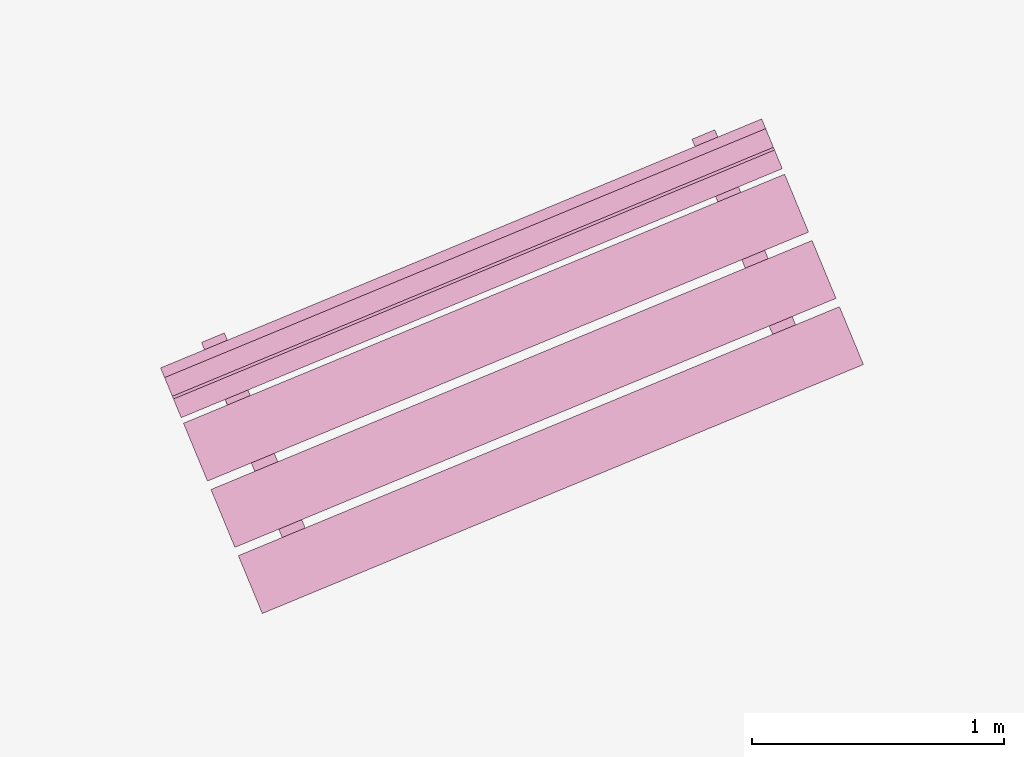
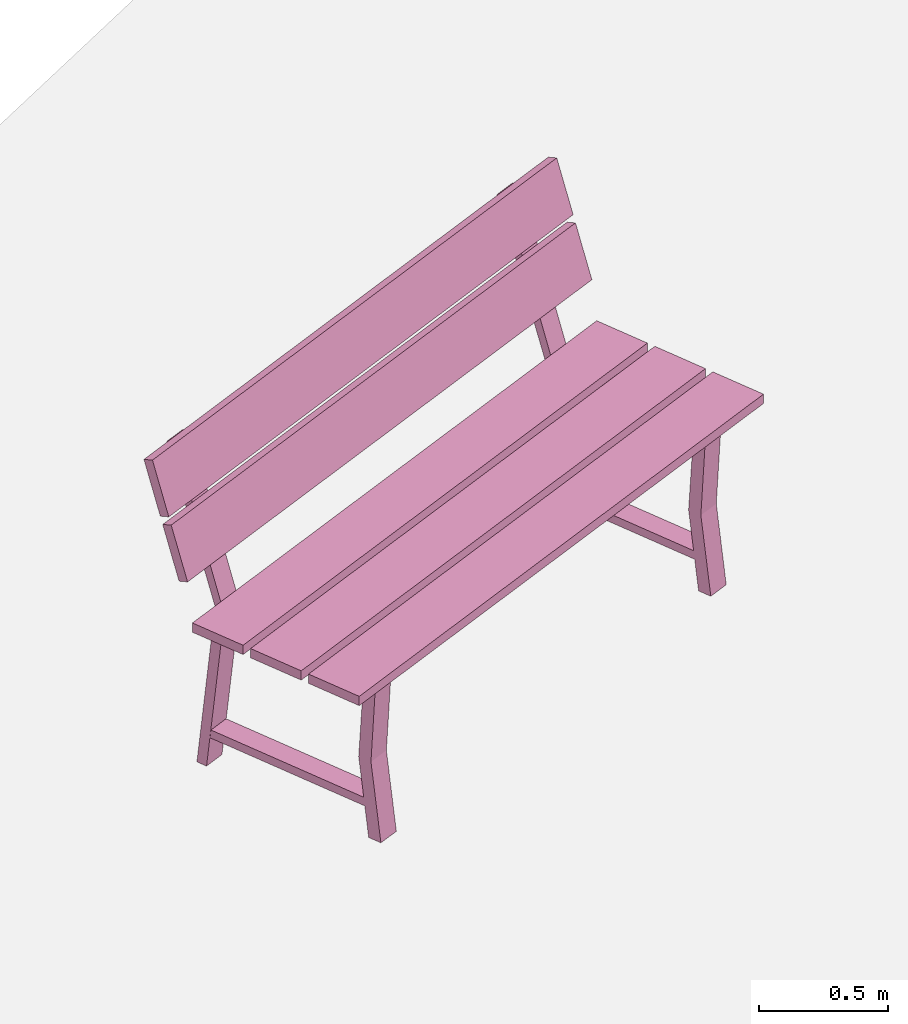
# One storey, part 17 of 200: 1 furnishing.
"""IFC4 building model written with IfcOpenShell, lengths in metres."""

import ifcopenshell
import ifcopenshell.guid

model = None  # the IFC model being written
_history = None  # IfcOwnerHistory: only IFC2X3 demands one
_inside = {}  # id of a spatial element -> (the spatial element, [elements in it])
_under = {}  # id of a project, library or spatial element -> (it, [spatial elements below it])
_declared = {}  # id of a project -> (the project, [libraries it declares])
_typed = {}  # id of a type object -> (the type object, [elements of that type])
_made_of = {}  # id of a material, layer set ... -> (it, [elements and type objects made of it])


def new_model(schema):
    """Start an empty IFC model of exactly this schema.

    Asked for "IFC4X3", IfcOpenShell would pick the latest addendum, in which some entities
    have other attributes; the version numbers below select the first issue.
    IFC2X3 requires an IfcOwnerHistory on every rooted entity: one is made here for all.
    """
    global model, _history
    if schema == "IFC4X3":
        model = ifcopenshell.file(schema_version=(4, 3, 0, 0))
    else:
        model = ifcopenshell.file(schema=schema)
    _inside.clear()
    _under.clear()
    _declared.clear()
    _typed.clear()
    _made_of.clear()
    _history = None
    if model.schema == "IFC2X3":
        org = make("IfcOrganization", Name="unknown")
        user = make(
            "IfcPersonAndOrganization",
            ThePerson=make("IfcPerson", FamilyName="unknown"),
            TheOrganization=org,
        )
        app = make(
            "IfcApplication",
            ApplicationDeveloper=org,
            Version="unknown",
            ApplicationFullName="unknown",
            ApplicationIdentifier="unknown",
        )
        _history = make(
            "IfcOwnerHistory",
            OwningUser=user,
            OwningApplication=app,
            ChangeAction="ADDED",
            CreationDate=0,
        )
    return model


def make(cls, **values):
    """One entity of the class cls with the attributes given. An attribute that is None is left unset."""
    return model.create_entity(
        cls, **{name: value for name, value in values.items() if value is not None}
    )


def rooted(cls, **values):
    """An entity with a GlobalId (a new one), such as an element, a storey or a relation."""
    return make(cls, GlobalId=ifcopenshell.guid.new(), OwnerHistory=_history, **values)


def si_unit(unit_type, name, prefix=None):
    """IfcSIUnit, for example si_unit("LENGTHUNIT", "METRE", prefix="MILLI")."""
    return make("IfcSIUnit", UnitType=unit_type, Prefix=prefix, Name=name)


def assignment(units):
    """IfcUnitAssignment: the units of a project."""
    return None if units is None else make("IfcUnitAssignment", Units=units)


def point(xyz):
    """IfcCartesianPoint."""
    return None if xyz is None else make("IfcCartesianPoint", Coordinates=xyz)


def direction(xyz):
    """IfcDirection."""
    return None if xyz is None else make("IfcDirection", DirectionRatios=xyz)


def frame(location, z_axis=None, x_axis=None):
    """IfcAxis2Placement3D, a coordinate frame: its origin and axes. An axis left out is left unset."""
    return make(
        "IfcAxis2Placement3D",
        Location=point(location),
        Axis=direction(z_axis),
        RefDirection=direction(x_axis),
    )


def origin_with_axes():
    """The frame at (0, 0, 0) with the z axis (0, 0, 1) and the x axis (1, 0, 0) written out."""
    return frame((0.0, 0.0, 0.0), z_axis=(0.0, 0.0, 1.0), x_axis=(1.0, 0.0, 0.0))


def place(relative_to, where):
    """IfcLocalPlacement: puts the frame where relative to a parent placement (None: the world)."""
    return make(
        "IfcLocalPlacement", PlacementRelTo=relative_to, RelativePlacement=where
    )


def context(
    kind, dimensions, precision=None, world=None, true_north=None, identifier=None
):
    """IfcGeometricRepresentationContext, for example the 3D "Model" context."""
    return make(
        "IfcGeometricRepresentationContext",
        ContextIdentifier=identifier,
        ContextType=kind,
        CoordinateSpaceDimension=dimensions,
        Precision=precision,
        WorldCoordinateSystem=world,
        TrueNorth=true_north,
    )


def subcontext(parent, identifier, kind, view, scale=None):
    """IfcGeometricRepresentationSubContext, for example "Body" below "Model"."""
    return make(
        "IfcGeometricRepresentationSubContext",
        ContextIdentifier=identifier,
        ContextType=kind,
        ParentContext=parent,
        TargetScale=scale,
        TargetView=view,
    )


def project(units=None, contexts=None):
    """IfcProject with its units and contexts."""
    return rooted(
        "IfcProject",
        Name="project",
        RepresentationContexts=contexts,
        UnitsInContext=assignment(units),
    )


def spatial(cls, under=None, at=None, **own):
    """A site, building, storey or space (cls), placed at a placement, below another one or the project."""
    s = rooted(cls, ObjectPlacement=at, **own)
    if under is not None:
        _under.setdefault(under.id(), (under, []))[1].append(s)
    return s


def point_list(points):
    """IfcCartesianPointList2D or 3D."""
    cls = (
        "IfcCartesianPointList2D" if len(points[0]) == 2 else "IfcCartesianPointList3D"
    )
    return make(cls, CoordList=points)


def triangles(points, corners, closed=None, point_numbers=None):
    """IfcTriangulatedFaceSet: each triangle names its three corners, points numbered from 1."""
    return make(
        "IfcTriangulatedFaceSet",
        Coordinates=point_list(points),
        Closed=closed,
        CoordIndex=corners,
        PnIndex=point_numbers,
    )


def shape(context_of_items, identifier, shape_type, items):
    """IfcShapeRepresentation: the items that make up one representation, for example the "Body"."""
    return make(
        "IfcShapeRepresentation",
        ContextOfItems=context_of_items,
        RepresentationIdentifier=identifier,
        RepresentationType=shape_type,
        Items=items,
    )


def material(Name=None, Category=None):
    """IfcMaterial."""
    return make("IfcMaterial", Name=Name, Category=Category)


def made_of(thing, what):
    """Note that an element or type object is made of a material, layer set ...; save() writes the relation."""
    if what is not None:
        _made_of.setdefault(what.id(), (what, []))[1].append(thing)
    return thing


def element(
    cls,
    number,
    at=None,
    inside=None,
    cuts=None,
    type_object=None,
    material=None,
    context=None,
    identifier="Body",
    shape_type=None,
    held_by="IfcProductDefinitionShape",
    body=None,
    shapes=None,
    **own,
):
    """One element of the class cls, such as IfcWall. Its Tag is "e" and its number.

    at: its placement. inside: the storey or other place that contains it. cuts: it is an
    opening in that element (IfcRelVoidsElement). A single representation is given by context,
    identifier, shape_type and body (its items); several are given by shapes. held_by: the class
    of the entity that holds the representations. save() writes the other relations.
    """
    e = rooted(cls, Tag="e%d" % number, ObjectPlacement=at, **own)
    if body is not None:
        shapes = [shape(context, identifier, shape_type, body)]
    if shapes is not None:
        e.Representation = make(held_by, Representations=shapes)
    if inside is not None:
        _inside.setdefault(inside.id(), (inside, []))[1].append(e)
    if cuts is not None:
        rooted(
            "IfcRelVoidsElement", RelatingBuildingElement=cuts, RelatedOpeningElement=e
        )
    if type_object is not None:
        _typed.setdefault(type_object.id(), (type_object, []))[1].append(e)
    return made_of(e, material)


def aggregate(whole, parts):
    """IfcRelAggregates: a whole, such as a stair, and the parts it consists of."""
    return rooted("IfcRelAggregates", RelatingObject=whole, RelatedObjects=parts)


def save(model, path):
    """Write the relations noted so far, then the file.

    IfcRelAggregates (storeys below a building ...), IfcRelContainedInSpatialStructure (elements
    in a storey), IfcRelDefinesByType, IfcRelAssociatesMaterial and IfcRelDeclares: one each for
    every whole, place, type object, material and project.
    """
    for whole, parts in _under.values():
        aggregate(whole, parts)
    for where, things in _inside.values():
        rooted(
            "IfcRelContainedInSpatialStructure",
            RelatedElements=things,
            RelatingStructure=where,
        )
    for kind, things in _typed.values():
        rooted("IfcRelDefinesByType", RelatedObjects=things, RelatingType=kind)
    for what, things in _made_of.values():
        rooted("IfcRelAssociatesMaterial", RelatedObjects=things, RelatingMaterial=what)
    for by, libraries in _declared.values():
        rooted("IfcRelDeclares", RelatingContext=by, RelatedDefinitions=libraries)
    model.write(path)


model = new_model("IFC4")

# Units and contexts
model_context = context("Model", 3, precision=1e-05, world=origin_with_axes())
body_context = subcontext(model_context, "Body", "Model", "MODEL_VIEW")
ifc_project = project(units=[si_unit("VOLUMEUNIT", "CUBIC_METRE"), si_unit("LENGTHUNIT", "METRE"), si_unit("AREAUNIT", "SQUARE_METRE")], contexts=[model_context])

# Site, building, storey
site_placement = place(None, origin_with_axes())
site = spatial("IfcSite", under=ifc_project, at=site_placement)
building_placement = place(site_placement, origin_with_axes())
building = spatial("IfcBuilding", under=site, at=building_placement, Name="Building")
storey_placement = place(building_placement, origin_with_axes())
storey = spatial("IfcBuildingStorey", under=building, at=storey_placement, Name="Ground")

# Furnishing
ifc_material = material(Name="bench")
furnishing_placement = place(storey_placement, origin_with_axes())
element("IfcFurnishingElement", 1, at=furnishing_placement, inside=storey, material=ifc_material, Name="cw_instances_bench_37", context=body_context, shape_type="Tessellation", body=[
    triangles([(250.3482450853043, -634.6445748261848, 0.815520754558246), (250.25323556842704, -634.4152015619851, 0.815520754558246), (247.8701290724751, -635.4023165931878, 0.815520754558246), (247.96513858935236, -635.6316898573875, 0.815520754558246), (248.19161628829997, -635.6858973220228, 0.36316797911391596), (248.2824747587563, -635.6482625113034, 0.36316797911391596), (248.30116920520555, -635.6933948974622, 1.4462435886752271e-07), (248.21031073474924, -635.7310297081817, 1.4462435886752271e-07), (248.30541232995466, -635.7036387067783, 0.36316797911391596), (248.2331868234176, -635.786257471699, 1.6069373207502523e-07), (248.32404529387392, -635.7486226609794, 1.6069373207502523e-07), (248.21455385949832, -635.7412735174978, 0.36316797911391596), (248.01374232549728, -634.9994850262799, 0.7742224172068448), (248.01374232549728, -634.9994850262799, 0.7742224172068448), (247.97936676531006, -634.9164950826618, 0.0), (247.88850829485375, -634.9541298933813, 0.0), (247.88850829485375, -634.9541298933813, 0.0), (247.92243848493692, -635.0373043153368, 0.7742224172068448), (248.0300384613185, -635.0388273783938, 0.7346917591163886), (247.90652629203507, -634.9976291865432, 1.6069373207502518e-08), (247.99738476249138, -634.9599943758237, 1.6069373207502518e-08), (247.9391799908622, -635.0764621891133, 0.7353345501140619), (248.20084049419404, -635.7081665249943, 0.7353346465303011), (248.29182195430826, -635.670828637575, 0.7346918555326278), (248.31494399769448, -635.7266501883079, 0.7742225618312036), (248.22364015713413, -635.7644694773647, 0.7742225618312036), (250.45690644190952, -634.906906547007, 0.8155208509744852), (250.36189693118175, -634.6775332976534, 0.815520754558246), (247.97879043522977, -635.6646483288562, 0.815520754558246), (248.07379994595757, -635.8940215782096, 0.8155208509744852), (250.2393992319133, -634.3817976907201, 0.815520754558246), (250.1443897211855, -634.1524244413666, 0.8155206581420068), (247.76128322523354, -635.1395394725694, 0.8155206581420068), (247.85629273596132, -635.3689127219228, 0.815520754558246), (250.13528848035142, -634.1304521023105, 0.9999971268416286), (247.72149604015544, -635.0434847107451, 1.2349312667190762), (247.75218198439944, -635.1175671335133, 0.9999971268416286), (250.10460253610742, -634.0563696795425, 1.2349312667190762), (250.10017490227352, -634.0456804258914, 1.2691590637898031), (247.68638247437653, -634.9587130640184, 1.5040931072510113), (247.71706840632157, -635.0327954570942, 1.2691590637898031), (250.0694889703285, -633.9715980328157, 1.5040931072510113), (247.8324609240525, -634.8192395675982, 1.4584561837579435), (247.9233194835858, -634.7816047199817, 1.4584561837579435), (248.01374232549728, -634.9994850262799, 0.7742224172068448), (247.92243848493692, -635.0373043153368, 0.7742224172068448), (247.93758111916, -635.0726021713654, 0.7739010297426947), (248.02825511127895, -635.0345219905419, 0.7739010297426947), (247.93789375804695, -634.8167901310476, 1.4724364581016047), (247.847219676851, -634.854870348768, 1.4724364581016047), (247.7362548175519, -635.0791155512998, 0.9858560302109066), (247.70563036198737, -635.0051815753355, 1.2207902665045935), (250.11936131350387, -634.092000520097, 0.9858560302109066), (250.08873685793935, -634.0180665441328, 1.2207902665045935), (247.70114124562352, -634.9943438897269, 1.2550180635753205), (247.670455307529, -634.9202614818049, 1.4899522998690073), (250.08424774157547, -634.0072288585242, 1.2550180635753205), (250.05356180348096, -633.9331464506022, 1.4899522998690073), (250.13601853407323, -634.8804995411149, 0.36316797911391596), (250.22687700452954, -634.8428647303954, 0.36316797911391596), (250.24557145097882, -634.8879971165542, 1.4462435886752271e-07), (250.15471298052248, -634.9256319272737, 1.4462435886752271e-07), (250.2498145757279, -634.8982409258704, 0.36316797911391596), (250.17758906919084, -634.9808596907909, 1.6069373207502523e-07), (250.26844753964718, -634.9432248800715, 1.6069373207502523e-07), (250.15895610527159, -634.9358757365899, 0.36316797911391596), (249.9581445712705, -634.1940872453719, 0.7742224172068448), (249.9581445712705, -634.1940872453719, 0.7742224172068448), (249.92376901108332, -634.1110973017538, 0.0), (249.83291054062698, -634.1487321124732, 0.0), (249.83291054062698, -634.1487321124732, 0.0), (249.86698913297556, -634.2318450641977, 0.7742224172068448), (249.97444070709176, -634.2334295974858, 0.7346917591163886), (249.8509285378083, -634.1922314056352, 1.6069373207502518e-08), (249.94178700826464, -634.1545965949157, 1.6069373207502518e-08), (249.88358223663542, -634.2710644082053, 0.7353345501140619), (250.14524273996727, -634.9027687440864, 0.7353346465303011), (250.2362242000815, -634.8654308566671, 0.7346918555326278), (250.25934624346775, -634.9212524074, 0.7742225618312036), (250.1681908051728, -634.9590102262257, 0.7742225618312036), (249.77701166116813, -634.0137802795623, 1.4584561837579435), (249.86772174420523, -633.9762069329244, 1.4584561837579435), (249.9581445712705, -634.1940872453719, 0.7742224172068448), (249.86698913297556, -634.2318450641977, 0.7742224172068448), (249.88198336493326, -634.2672043904574, 0.7739010297426947), (249.9726573570522, -634.2291242096338, 0.7739010297426947), (249.88229601866638, -634.0113923439902, 1.4724364581016047), (249.79177041396667, -634.0494110607322, 1.4724364581016047), (250.25323556842704, -634.4152015619851, 0.815520754558246), (247.8701290724751, -635.4023165931878, 0.7716513657017641), (247.8701290724751, -635.4023165931878, 0.815520754558246), (250.25323556842704, -634.4152015619851, 0.7716513657017641), (250.3482450853043, -634.6445748261848, 0.7716514139098837), (247.96513858935236, -635.6316898573875, 0.815520754558246), (247.96513858935236, -635.6316898573875, 0.7716514139098837), (250.3482450853043, -634.6445748261848, 0.815520754558246), (248.21031073474924, -635.7310297081817, 1.4462435886752271e-07), (248.21455385949832, -635.7412735174978, 0.36316797911391596), (248.19161628829997, -635.6858973220228, 0.36316797911391596), (248.2331868234176, -635.786257471699, 1.6069373207502523e-07), (247.9391799908622, -635.0764621891133, 0.7353345501140619), (247.92243848493692, -635.0373043153368, 0.7742224172068448), (247.88850829485375, -634.9541298933813, 0.0), (247.90652629203507, -634.9976291865432, 1.6069373207502518e-08), (248.30541232995466, -635.7036387067783, 0.36316797911391596), (248.2824747587563, -635.6482625113034, 0.36316797911391596), (248.29182195430826, -635.670828637575, 0.7346918555326278), (248.31494399769448, -635.7266501883079, 0.7742225618312036), (248.01374232549728, -634.9994850262799, 0.7742224172068448), (248.0300384613185, -635.0388273783938, 0.7346917591163886), (247.97936676531006, -634.9164950826618, 0.0), (247.99738476249138, -634.9599943758237, 1.6069373207502518e-08), (248.20084049419404, -635.7081665249943, 0.7353346465303011), (248.22364015713413, -635.7644694773647, 0.7742225618312036), (248.30116920520555, -635.6933948974622, 1.4462435886752271e-07), (248.32404529387392, -635.7486226609794, 1.6069373207502523e-07), (247.8324609240525, -634.8192395675982, 1.4584561837579435), (247.93789375804695, -634.8167901310476, 1.4724364581016047), (247.9233194835858, -634.7816047199817, 1.4584561837579435), (247.847219676851, -634.854870348768, 1.4724364581016047), (248.00065015666846, -634.9708171254388, 0.13996424063734697), (248.00065015666846, -634.9708171254388, 0.17949489872780322), (248.2969322364002, -635.6861053406152, 0.13996438526170585), (248.29711672703652, -635.6865507404116, 0.17949504335216207), (247.91157316662827, -635.0077140228087, 0.17949489872780322), (247.9118701344669, -635.0075910147024, 0.1406070155656471), (248.20802923069024, -635.722582321425, 0.14060716019000596), (248.20803973699634, -635.7234476377816, 0.17949504335216207), (250.36189693118175, -634.6775332976534, 0.815520754558246), (247.97879043522977, -635.6646483288562, 0.7716514139098837), (247.97879043522977, -635.6646483288562, 0.815520754558246), (250.36189693118175, -634.6775332976534, 0.7716514139098837), (250.45690644190952, -634.906906547007, 0.7716514621180032), (248.07379994595757, -635.8940215782096, 0.8155208509744852), (248.07379994595757, -635.8940215782096, 0.7716514621180032), (250.45690644190952, -634.906906547007, 0.8155208509744852), (250.1443897211855, -634.1524244413666, 0.8155206581420068), (247.76128322523354, -635.1395394725694, 0.7716513174936444), (247.76128322523354, -635.1395394725694, 0.8155206581420068), (250.1443897211855, -634.1524244413666, 0.7716513174936444), (250.2393992380628, -634.3817977055662, 0.7716513657017641), (247.85629273596132, -635.3689127219228, 0.815520754558246), (247.8562927421108, -635.368912736769, 0.7716513657017641), (250.2393992319133, -634.3817976907201, 0.815520754558246), (247.70563036198737, -635.0051815753355, 1.2207902665045935), (250.10460253610742, -634.0563696795425, 1.2349312667190762), (250.08873685793935, -634.0180665441328, 1.2207902665045935), (247.72149604015544, -635.0434847107451, 1.2349312667190762), (250.11936131350387, -634.092000520097, 0.9858560302109066), (247.75218198439944, -635.1175671335133, 0.9999971268416286), (247.7362548175519, -635.0791155512998, 0.9858560302109066), (250.13528848035142, -634.1304521023105, 0.9999971268416286), (247.670455307529, -634.9202614818049, 1.4899522998690073), (250.0694889703285, -633.9715980328157, 1.5040931072510113), (250.05356180348096, -633.9331464506022, 1.4899522998690073), (247.68638247437653, -634.9587130640184, 1.5040931072510113), (250.08424774157547, -634.0072288585242, 1.2550180635753205), (247.71706840632157, -635.0327954570942, 1.2691590637898031), (247.70114124562352, -634.9943438897269, 1.2550180635753205), (250.10017490227352, -634.0456804258914, 1.2691590637898031), (250.15471298052248, -634.9256319272737, 1.4462435886752271e-07), (250.15895610527159, -634.9358757365899, 0.36316797911391596), (250.13601853407323, -634.8804995411149, 0.36316797911391596), (250.17758906919084, -634.9808596907909, 1.6069373207502523e-07), (249.88358223663542, -634.2710644082053, 0.7353345501140619), (249.86698913297556, -634.2318450641977, 0.7742224172068448), (249.83291054062698, -634.1487321124732, 0.0), (249.8509285378083, -634.1922314056352, 1.6069373207502518e-08), (250.2498145757279, -634.8982409258704, 0.36316797911391596), (250.22687700452954, -634.8428647303954, 0.36316797911391596), (250.2362242000815, -634.8654308566671, 0.7346918555326278), (250.25934624346775, -634.9212524074, 0.7742225618312036), (249.9581445712705, -634.1940872453719, 0.7742224172068448), (249.97444070709176, -634.2334295974858, 0.7346917591163886), (249.92376901108332, -634.1110973017538, 0.0), (249.94178700826464, -634.1545965949157, 1.6069373207502518e-08), (250.14524273996727, -634.9027687440864, 0.7353346465303011), (250.1681908051728, -634.9590102262257, 0.7742225618312036), (250.24557145097882, -634.8879971165542, 1.4462435886752271e-07), (250.26844753964718, -634.9432248800715, 1.6069373207502523e-07), (249.77701166116813, -634.0137802795623, 1.4584561837579435), (249.88229601866638, -634.0113923439902, 1.4724364581016047), (249.86772174420523, -633.9762069329244, 1.4584561837579435), (249.79177041396667, -634.0494110607322, 1.4724364581016047), (249.9452008937841, -634.1653578374028, 0.13996424063734697), (249.9452008937841, -634.1653578374028, 0.17949489872780322), (250.24148297351584, -634.8806460525793, 0.13996438526170585), (250.2416674641522, -634.8810914523757, 0.17949504335216207), (249.85597541240153, -634.2023162419008, 0.17949489872780322), (249.85642078250555, -634.2021317635634, 0.1406070155656471), (250.1525798787289, -634.9171230702859, 0.14060716019000596), (250.1524419827696, -634.9180498568736, 0.17949504335216207), (250.3482450853043, -634.6445748261848, 0.815520754558246), (250.25323556842704, -634.4152015619851, 0.7716513657017641), (250.25323556842704, -634.4152015619851, 0.815520754558246), (250.3482450853043, -634.6445748261848, 0.7716514139098837), (247.8701290724751, -635.4023165931878, 0.815520754558246), (247.8701290724751, -635.4023165931878, 0.7716513657017641), (247.96513858935236, -635.6316898573875, 0.7716514139098837), (247.96513858935236, -635.6316898573875, 0.815520754558246), (250.45690644190952, -634.906906547007, 0.8155208509744852), (250.36189693118175, -634.6775332976534, 0.7716514139098837), (250.36189693118175, -634.6775332976534, 0.815520754558246), (250.45690644190952, -634.906906547007, 0.7716514621180032), (247.97879043522977, -635.6646483288562, 0.815520754558246), (247.97879043522977, -635.6646483288562, 0.7716514139098837), (248.07379994595757, -635.8940215782096, 0.7716514621180032), (248.07379994595757, -635.8940215782096, 0.8155208509744852), (250.2393992319133, -634.3817976907201, 0.815520754558246), (250.1443897211855, -634.1524244413666, 0.7716513174936444), (250.1443897211855, -634.1524244413666, 0.8155206581420068), (250.2393992380628, -634.3817977055662, 0.7716513657017641), (247.76128322523354, -635.1395394725694, 0.8155206581420068), (247.76128322523354, -635.1395394725694, 0.7716513174936444), (247.8562927421108, -635.368912736769, 0.7716513657017641), (247.85629273596132, -635.3689127219228, 0.815520754558246), (250.11936131350387, -634.092000520097, 0.9858560302109066), (250.08873685793935, -634.0180665441328, 1.2207902665045935), (250.10460253610742, -634.0563696795425, 1.2349312667190762), (250.13528848035142, -634.1304521023105, 0.9999971268416286), (247.72149604015544, -635.0434847107451, 1.2349312667190762), (247.7362548175519, -635.0791155512998, 0.9858560302109066), (247.75218198439944, -635.1175671335133, 0.9999971268416286), (247.70563036198737, -635.0051815753355, 1.2207902665045935), (250.08424774157547, -634.0072288585242, 1.2550180635753205), (250.05356180348096, -633.9331464506022, 1.4899522998690073), (250.0694889703285, -633.9715980328157, 1.5040931072510113), (250.10017490227352, -634.0456804258914, 1.2691590637898031), (247.68638247437653, -634.9587130640184, 1.5040931072510113), (247.70114124562352, -634.9943438897269, 1.2550180635753205), (247.71706840632157, -635.0327954570942, 1.2691590637898031), (247.670455307529, -634.9202614818049, 1.4899522998690073), (248.02825511127895, -635.0345219905419, 0.7739010297426947), (247.93789375804695, -634.8167901310476, 1.4724364581016047), (247.9233194835858, -634.7816047199817, 1.4584561837579435), (247.92243848493692, -635.0373043153368, 0.7742224172068448), (247.93758111916, -635.0726021713654, 0.7739010297426947), (247.847219676851, -634.854870348768, 1.4724364581016047), (247.8324609240525, -634.8192395675982, 1.4584561837579435), (249.9726573570522, -634.2291242096338, 0.7739010297426947), (249.88229601866638, -634.0113923439902, 1.4724364581016047), (249.86772174420523, -633.9762069329244, 1.4584561837579435), (249.86698913297556, -634.2318450641977, 0.7742224172068448), (249.88198336493326, -634.2672043904574, 0.7739010297426947), (249.79177041396667, -634.0494110607322, 1.4724364581016047), (249.77701166116813, -634.0137802795623, 1.4584561837579435), (248.01374232549728, -634.9994850262799, 0.7742224172068448), (247.92243848493692, -635.0373043153368, 0.7742224172068448), (248.31494399769448, -635.7266501883079, 0.7742225618312036), (248.22364015713413, -635.7644694773647, 0.7742225618312036), (248.00065015666846, -634.9708171254388, 0.17949489872780322), (247.91157316662827, -635.0077140228087, 0.17949489872780322), (248.29711672703652, -635.6865507404116, 0.17949504335216207), (248.20803973699634, -635.7234476377816, 0.17949504335216207), (249.9581445712705, -634.1940872453719, 0.7742224172068448), (249.86698913297556, -634.2318450641977, 0.7742224172068448), (250.25934624346775, -634.9212524074, 0.7742225618312036), (250.1681908051728, -634.9590102262257, 0.7742225618312036), (249.9452008937841, -634.1653578374028, 0.17949489872780322), (249.85597541240153, -634.2023162419008, 0.17949489872780322), (250.2416674641522, -634.8810914523757, 0.17949504335216207), (250.1524419827696, -634.9180498568736, 0.17949504335216207)], [[1, 2, 3], [3, 4, 1], [5, 6, 7], [7, 8, 5], [9, 10, 11], [10, 9, 12], [14, 15, 16], [17, 18, 13], [19, 20, 21], [20, 19, 22], [23, 24, 5], [24, 6, 5], [12, 9, 25], [25, 26, 12], [27, 28, 29], [29, 30, 27], [31, 32, 33], [33, 34, 31], [35, 36, 37], [35, 38, 36], [39, 40, 41], [39, 42, 40], [43, 44, 45], [45, 46, 43], [47, 48, 49], [49, 50, 47], [51, 52, 53], [54, 53, 52], [55, 56, 57], [58, 57, 56], [59, 60, 61], [61, 62, 59], [63, 64, 65], [64, 63, 66], [68, 69, 71], [70, 72, 67], [73, 74, 75], [74, 73, 76], [77, 78, 59], [78, 60, 59], [66, 63, 79], [79, 80, 66], [81, 82, 83], [83, 84, 81], [85, 86, 87], [87, 88, 85], [89, 90, 91], [89, 92, 90], [93, 94, 95], [93, 96, 94], [97, 98, 99], [97, 100, 98], [101, 102, 103], [103, 104, 101], [105, 106, 107], [107, 108, 105], [109, 110, 111], [110, 112, 111], [108, 107, 109], [107, 110, 109], [113, 99, 98], [98, 114, 113], [115, 106, 105], [105, 116, 115], [117, 118, 119], [117, 120, 118], [102, 101, 113], [113, 114, 102], [121, 122, 123], [122, 124, 123], [125, 126, 127], [127, 128, 125], [129, 130, 131], [129, 132, 130], [133, 134, 135], [133, 136, 134], [137, 138, 139], [137, 140, 138], [141, 142, 143], [141, 144, 142], [145, 146, 147], [145, 148, 146], [149, 150, 151], [149, 152, 150], [153, 154, 155], [153, 156, 154], [157, 158, 159], [157, 160, 158], [161, 162, 163], [161, 164, 162], [165, 166, 167], [167, 168, 165], [169, 170, 171], [171, 172, 169], [173, 174, 175], [174, 176, 175], [172, 171, 173], [171, 174, 173], [177, 163, 162], [162, 178, 177], [179, 170, 169], [169, 180, 179], [181, 182, 183], [181, 184, 182], [166, 165, 177], [177, 178, 166], [185, 186, 187], [186, 188, 187], [189, 190, 191], [191, 192, 189], [193, 194, 195], [194, 193, 196], [197, 198, 199], [199, 200, 197], [201, 202, 203], [202, 201, 204], [205, 206, 207], [207, 208, 205], [209, 210, 211], [210, 209, 212], [213, 214, 215], [215, 216, 213], [217, 218, 219], [219, 220, 217], [221, 222, 223], [222, 221, 224], [225, 226, 227], [227, 228, 225], [229, 230, 231], [230, 229, 232], [233, 109, 234], [109, 235, 234], [236, 237, 238], [238, 239, 236], [240, 173, 241], [173, 242, 241], [243, 244, 245], [245, 246, 243], [247, 248, 249], [248, 250, 249], [251, 252, 253], [252, 254, 253], [255, 256, 257], [256, 258, 257], [259, 260, 261], [260, 262, 261]], closed=True),
])

save(model, "model.ifc")
